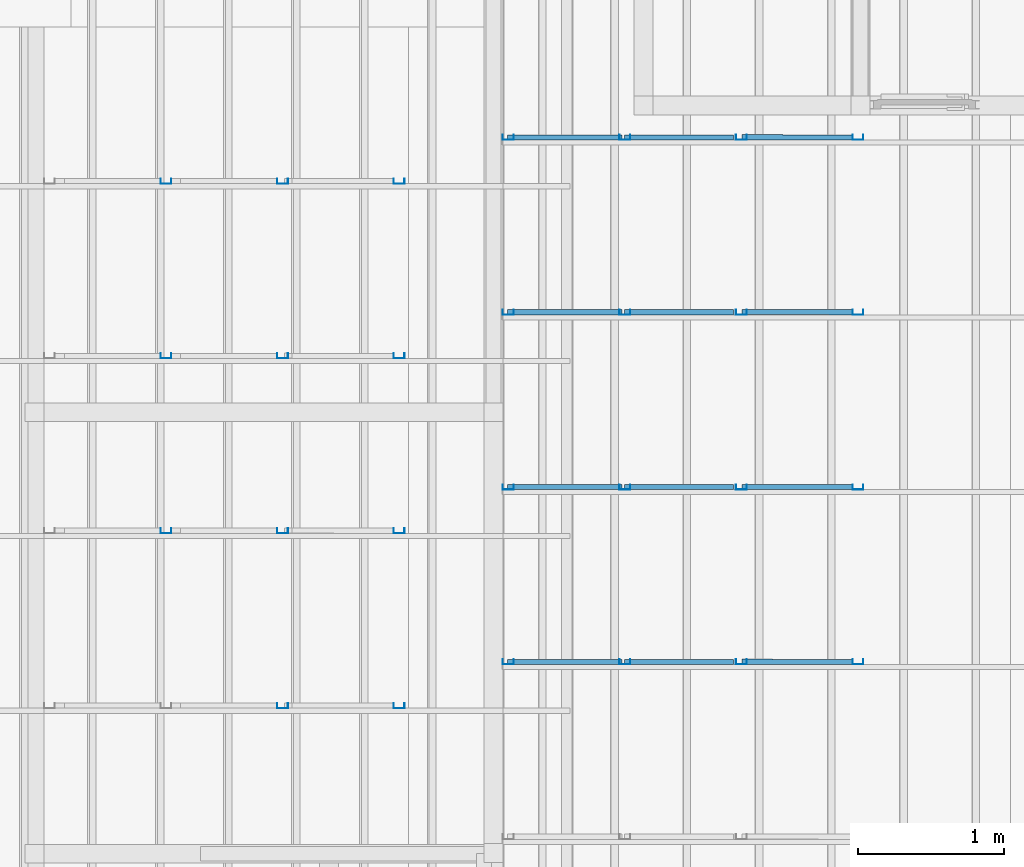
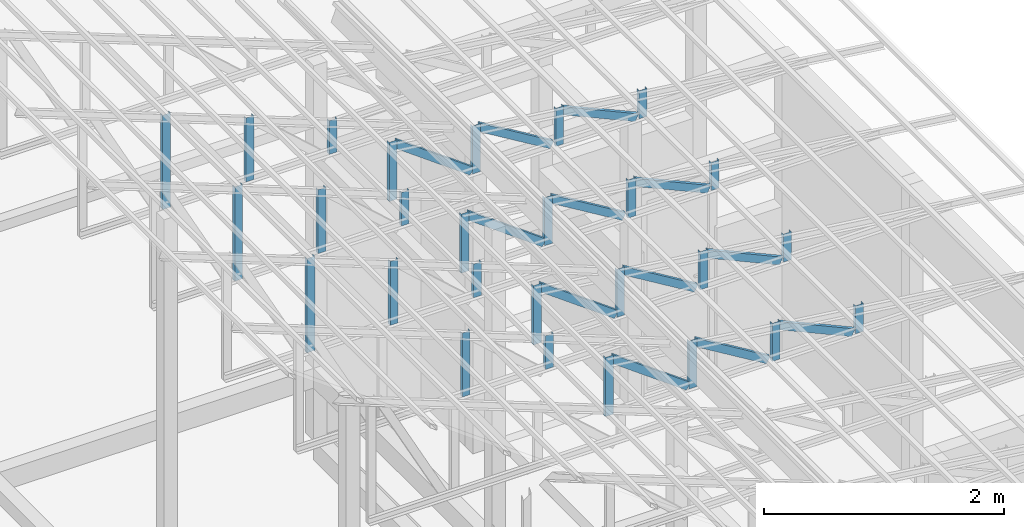
# One storey, part 18 of 22: 39 members, 2 elements without a shape of their own.
"""IFC4 building model written with IfcOpenShell, lengths in millimetres."""

from ifc_helpers import new_model, entity, si_unit, converted_unit, frame, origin_with_axes, origin_2d_with_axis, place, context, subcontext, project, spatial, c_section, extrude, material, material_profile, profile_set, profile_usage, type_object, element, aggregate, save


model = new_model("IFC4")

# Units and contexts
model_context = context("Model", 3, precision=1e-05, world=origin_with_axes())
plan_context = context("Plan", 2, precision=1e-05, world=origin_2d_with_axis())
body_context = subcontext(model_context, "Body", "Model", "MODEL_VIEW")
ifc_project = project(units=[si_unit("VOLUMEUNIT", "CUBIC_METRE"), si_unit("LENGTHUNIT", "METRE", prefix="MILLI"), si_unit("AREAUNIT", "SQUARE_METRE"), converted_unit("PLANEANGLEUNIT", "degree", entity("IfcReal", 0.0174532925199433), si_unit("PLANEANGLEUNIT", "RADIAN"), dimensions=[0, 0, 0, 0, 0, 0, 0])], contexts=[model_context, plan_context])

# Site, building, storey
site_placement = place(None, origin_with_axes())
site = spatial("IfcSite", under=ifc_project, at=site_placement)
building_placement = place(site_placement, origin_with_axes())
building = spatial("IfcBuilding", under=site, at=building_placement, Name="2")
storey_placement = place(building_placement, frame((0.0, 0.0, 200.000002980232), z_axis=(0.0, 0.0, 1.0), x_axis=(1.0, 0.0, 0.0)))
storey = spatial("IfcBuildingStorey", under=building, at=storey_placement)

# Assembly, members
assembly_1_placement = place(storey_placement, frame((-1561.45393848419, 6600.0657081604, 3019.63977515697), z_axis=(0.0, 0.0, 1.0), x_axis=(1.0, 0.0, 0.0)))
assembly_1 = element("IfcElementAssembly", 1, at=assembly_1_placement, inside=storey, Name="K1")
ifc_material = material(Name="STEEL")
ifc_material_profile = material_profile(ifc_material, c_section(Depth=75.0, Width=35.0, WallThickness=1.0, Girth=1.0, kind="CURVE"))
ifc_profile_set = profile_set([ifc_material_profile])
ifc_profile_usage_1 = profile_usage(ifc_profile_set, cardinal=9)
member_type = type_object("IfcMemberType", Name="C75", PredefinedType="CHORD", material=ifc_profile_set)
member_1_placement = place(assembly_1_placement, frame((-702.355027198792, 5999.93181228638, 368.052959442139), z_axis=(0.912206913056706, -0.00121979383816088, -0.409728031594797), x_axis=(0.00137145876901944, 0.999999056639273, 7.62981516029096e-05)))
member_1 = element("IfcMember", 2, at=member_1_placement, type_object=member_type, material=ifc_profile_usage_1, Name="Member", context=body_context, shape_type="SweptSolid", body=[
    extrude(c_section(Depth=75.0, Width=35.0, WallThickness=1.0, Girth=1.0, kind="CURVE"), frame((17.5, -37.5, 0.0), z_axis=(0.0, 0.0, 1.0), x_axis=(1.0, 0.0, 0.0)), (0.0, 0.0, 1.0), 791.494517196627),
])
ifc_profile_usage_2 = profile_usage(ifc_profile_set, cardinal=9)
member_2_placement = place(assembly_1_placement, frame((-2299.51107501984, 5998.93236160278, 592.46301651001), z_axis=(-8.7422719730052e-08, 3.25841369885875e-07, -0.999999999999943), x_axis=(1.62920684942936e-07, 0.999999999999934, 3.25841369885871e-07)))
member_2 = element("IfcMember", 3, at=member_2_placement, type_object=member_type, material=ifc_profile_usage_2, Name="Member", context=body_context, shape_type="SweptSolid", body=[
    extrude(c_section(Depth=75.0, Width=35.0, WallThickness=1.0, Girth=1.0, kind="CURVE"), frame((17.5, -37.5, 0.0), z_axis=(0.0, 0.0, 1.0), x_axis=(1.0, 0.0, 0.0)), (0.0, 0.0, 1.0), 601.479041515268),
])
ifc_profile_usage_3 = profile_usage(ifc_profile_set, cardinal=9)
member_3_placement = place(assembly_1_placement, frame((-1499.51112270355, 5998.93236160278, 479.381561279297), z_axis=(-8.7422719730052e-08, 3.25841369885875e-07, -0.999999999999943), x_axis=(1.62920684942936e-07, 0.999999999999934, 3.25841369885871e-07)))
member_3 = element("IfcMember", 4, at=member_3_placement, type_object=member_type, material=ifc_profile_usage_3, Name="Member", context=body_context, shape_type="SweptSolid", body=[
    extrude(c_section(Depth=75.0, Width=35.0, WallThickness=1.0, Girth=1.0, kind="CURVE"), frame((17.5, -37.5, 0.0), z_axis=(0.0, 0.0, 1.0), x_axis=(1.0, 0.0, 0.0)), (0.0, 0.0, 1.0), 488.397843745656),
])
ifc_profile_usage_4 = profile_usage(ifc_profile_set, cardinal=9)
member_4_placement = place(assembly_1_placement, frame((-699.511170387268, 5998.93236160278, 377.824306488037), z_axis=(-8.7422719730052e-08, 3.25841369885875e-07, -0.999999999999943), x_axis=(1.62920684942936e-07, 0.999999999999934, 3.25841369885871e-07)))
member_4 = element("IfcMember", 5, at=member_4_placement, type_object=member_type, material=ifc_profile_usage_4, Name="Member", context=body_context, shape_type="SweptSolid", body=[
    extrude(c_section(Depth=75.0, Width=35.0, WallThickness=1.0, Girth=1.0, kind="CURVE"), frame((17.5, -37.5, 0.0), z_axis=(0.0, 0.0, 1.0), x_axis=(1.0, 0.0, 0.0)), (0.0, 0.0, 1.0), 386.840589191612),
])
ifc_profile_usage_5 = profile_usage(ifc_profile_set, cardinal=9)
member_5_placement = place(assembly_1_placement, frame((-2299.51107501984, 5998.93236160278, 592.46301651001), z_axis=(0.807471586940316, -1.26964538798404e-07, -0.589906464012789), x_axis=(7.54979012640426e-08, 0.999999999999991, -1.1188575399501e-07)))
member_5 = element("IfcMember", 6, at=member_5_placement, type_object=member_type, material=ifc_profile_usage_5, Name="Member", context=body_context, shape_type="SweptSolid", body=[
    extrude(c_section(Depth=75.0, Width=35.0, WallThickness=1.0, Girth=1.0, kind="CURVE"), frame((17.5, -37.5, 0.0), z_axis=(0.0, 0.0, 1.0), x_axis=(1.0, 0.0, 0.0)), (0.0, 0.0, 1.0), 921.685377112707),
])
ifc_profile_usage_6 = profile_usage(ifc_profile_set, cardinal=9)
member_6_placement = place(assembly_1_placement, frame((-1499.51112270355, 5998.93236160278, 479.381561279297), z_axis=(0.855801528545197, -4.23314648434558e-08, -0.517304304775924), x_axis=(7.5497901264043e-08, 0.999999999999996, 4.30689546249139e-08)))
member_6 = element("IfcMember", 7, at=member_6_placement, type_object=member_type, material=ifc_profile_usage_6, Name="Member", context=body_context, shape_type="SweptSolid", body=[
    extrude(c_section(Depth=75.0, Width=35.0, WallThickness=1.0, Girth=1.0, kind="CURVE"), frame((17.5, -37.5, 0.0), z_axis=(0.0, 0.0, 1.0), x_axis=(1.0, 0.0, 0.0)), (0.0, 0.0, 1.0), 826.976096113964),
])
ifc_profile_usage_7 = profile_usage(ifc_profile_set, cardinal=9)
member_7_placement = place(assembly_1_placement, frame((100.488781929016, 5998.93236160278, 276.402950286865), z_axis=(-8.7422719730052e-08, 3.25841369885875e-07, -0.999999999999943), x_axis=(1.62920684942936e-07, 0.999999999999934, 3.25841369885871e-07)))
member_7 = element("IfcMember", 8, at=member_7_placement, type_object=member_type, material=ifc_profile_usage_7, Name="Member", context=body_context, shape_type="SweptSolid", body=[
    extrude(c_section(Depth=75.0, Width=35.0, WallThickness=1.0, Girth=1.0, kind="CURVE"), frame((17.5, -37.5, 0.0), z_axis=(0.0, 0.0, 1.0), x_axis=(1.0, 0.0, 0.0)), (0.0, 0.0, 1.0), 285.419225275215),
])
ifc_profile_usage_8 = profile_usage(ifc_profile_set, cardinal=9)
member_8_placement = place(assembly_1_placement, frame((-702.355027198792, 7199.93162155151, 368.052959442139), z_axis=(0.912206913056706, -0.00121979383816088, -0.409728031594797), x_axis=(0.00137145876901944, 0.999999056639273, 7.62981516029096e-05)))
member_8 = element("IfcMember", 9, at=member_8_placement, type_object=member_type, material=ifc_profile_usage_8, Name="Member", context=body_context, shape_type="SweptSolid", body=[
    extrude(c_section(Depth=75.0, Width=35.0, WallThickness=1.0, Girth=1.0, kind="CURVE"), frame((17.5, -37.5, 0.0), z_axis=(0.0, 0.0, 1.0), x_axis=(1.0, 0.0, 0.0)), (0.0, 0.0, 1.0), 791.494517196627),
])
ifc_profile_usage_9 = profile_usage(ifc_profile_set, cardinal=9)
member_9_placement = place(assembly_1_placement, frame((-699.511170387268, 7198.93217086792, 377.824306488037), z_axis=(-8.7422719730052e-08, 3.25841369885875e-07, -0.999999999999943), x_axis=(1.62920684942936e-07, 0.999999999999934, 3.25841369885871e-07)))
member_9 = element("IfcMember", 10, at=member_9_placement, type_object=member_type, material=ifc_profile_usage_9, Name="Member", context=body_context, shape_type="SweptSolid", body=[
    extrude(c_section(Depth=75.0, Width=35.0, WallThickness=1.0, Girth=1.0, kind="CURVE"), frame((17.5, -37.5, 0.0), z_axis=(0.0, 0.0, 1.0), x_axis=(1.0, 0.0, 0.0)), (0.0, 0.0, 1.0), 386.840589191612),
])
ifc_profile_usage_10 = profile_usage(ifc_profile_set, cardinal=9)
member_10_placement = place(assembly_1_placement, frame((-2299.51107501984, 7198.93217086792, 592.46301651001), z_axis=(-8.7422719730052e-08, 3.25841369885875e-07, -0.999999999999943), x_axis=(1.62920684942936e-07, 0.999999999999934, 3.25841369885871e-07)))
member_10 = element("IfcMember", 11, at=member_10_placement, type_object=member_type, material=ifc_profile_usage_10, Name="Member", context=body_context, shape_type="SweptSolid", body=[
    extrude(c_section(Depth=75.0, Width=35.0, WallThickness=1.0, Girth=1.0, kind="CURVE"), frame((17.5, -37.5, 0.0), z_axis=(0.0, 0.0, 1.0), x_axis=(1.0, 0.0, 0.0)), (0.0, 0.0, 1.0), 601.479041515268),
])
ifc_profile_usage_11 = profile_usage(ifc_profile_set, cardinal=9)
member_11_placement = place(assembly_1_placement, frame((100.488781929016, 7198.93217086792, 276.402950286865), z_axis=(-8.7422719730052e-08, 3.25841369885875e-07, -0.999999999999943), x_axis=(1.62920684942936e-07, 0.999999999999934, 3.25841369885871e-07)))
member_11 = element("IfcMember", 12, at=member_11_placement, type_object=member_type, material=ifc_profile_usage_11, Name="Member", context=body_context, shape_type="SweptSolid", body=[
    extrude(c_section(Depth=75.0, Width=35.0, WallThickness=1.0, Girth=1.0, kind="CURVE"), frame((17.5, -37.5, 0.0), z_axis=(0.0, 0.0, 1.0), x_axis=(1.0, 0.0, 0.0)), (0.0, 0.0, 1.0), 285.419225275215),
])
ifc_profile_usage_12 = profile_usage(ifc_profile_set, cardinal=9)
member_12_placement = place(assembly_1_placement, frame((-1499.51112270355, 7198.93217086792, 479.381561279297), z_axis=(-8.7422719730052e-08, 3.25841369885875e-07, -0.999999999999943), x_axis=(1.62920684942936e-07, 0.999999999999934, 3.25841369885871e-07)))
member_12 = element("IfcMember", 13, at=member_12_placement, type_object=member_type, material=ifc_profile_usage_12, Name="Member", context=body_context, shape_type="SweptSolid", body=[
    extrude(c_section(Depth=75.0, Width=35.0, WallThickness=1.0, Girth=1.0, kind="CURVE"), frame((17.5, -37.5, 0.0), z_axis=(0.0, 0.0, 1.0), x_axis=(1.0, 0.0, 0.0)), (0.0, 0.0, 1.0), 488.397843745656),
])
ifc_profile_usage_13 = profile_usage(ifc_profile_set, cardinal=9)
member_13_placement = place(assembly_1_placement, frame((-2299.51107501984, 7198.93217086792, 592.46301651001), z_axis=(0.807471586940316, -1.26964538798404e-07, -0.589906464012789), x_axis=(7.54979012640426e-08, 0.999999999999991, -1.1188575399501e-07)))
member_13 = element("IfcMember", 14, at=member_13_placement, type_object=member_type, material=ifc_profile_usage_13, Name="Member", context=body_context, shape_type="SweptSolid", body=[
    extrude(c_section(Depth=75.0, Width=35.0, WallThickness=1.0, Girth=1.0, kind="CURVE"), frame((17.5, -37.5, 0.0), z_axis=(0.0, 0.0, 1.0), x_axis=(1.0, 0.0, 0.0)), (0.0, 0.0, 1.0), 921.685377112707),
])
ifc_profile_usage_14 = profile_usage(ifc_profile_set, cardinal=9)
member_14_placement = place(assembly_1_placement, frame((-1499.51112270355, 7198.93217086792, 479.381561279297), z_axis=(0.855801528545197, -4.23314648434558e-08, -0.517304304775924), x_axis=(7.5497901264043e-08, 0.999999999999996, 4.30689546249139e-08)))
member_14 = element("IfcMember", 15, at=member_14_placement, type_object=member_type, material=ifc_profile_usage_14, Name="Member", context=body_context, shape_type="SweptSolid", body=[
    extrude(c_section(Depth=75.0, Width=35.0, WallThickness=1.0, Girth=1.0, kind="CURVE"), frame((17.5, -37.5, 0.0), z_axis=(0.0, 0.0, 1.0), x_axis=(1.0, 0.0, 0.0)), (0.0, 0.0, 1.0), 826.976096113964),
])
ifc_profile_usage_15 = profile_usage(ifc_profile_set, cardinal=9)
member_15_placement = place(assembly_1_placement, frame((-2299.51107501984, 8398.93198013306, 592.46301651001), z_axis=(-8.7422719730052e-08, 3.25841369885875e-07, -0.999999999999943), x_axis=(1.62920684942936e-07, 0.999999999999934, 3.25841369885871e-07)))
member_15 = element("IfcMember", 16, at=member_15_placement, type_object=member_type, material=ifc_profile_usage_15, Name="Member", context=body_context, shape_type="SweptSolid", body=[
    extrude(c_section(Depth=75.0, Width=35.0, WallThickness=1.0, Girth=1.0, kind="CURVE"), frame((17.5, -37.5, 0.0), z_axis=(0.0, 0.0, 1.0), x_axis=(1.0, 0.0, 0.0)), (0.0, 0.0, 1.0), 601.479041515268),
])
ifc_profile_usage_16 = profile_usage(ifc_profile_set, cardinal=9)
member_16_placement = place(assembly_1_placement, frame((-699.511170387268, 8398.93198013306, 377.824306488037), z_axis=(-8.7422719730052e-08, 3.25841369885875e-07, -0.999999999999943), x_axis=(1.62920684942936e-07, 0.999999999999934, 3.25841369885871e-07)))
member_16 = element("IfcMember", 17, at=member_16_placement, type_object=member_type, material=ifc_profile_usage_16, Name="Member", context=body_context, shape_type="SweptSolid", body=[
    extrude(c_section(Depth=75.0, Width=35.0, WallThickness=1.0, Girth=1.0, kind="CURVE"), frame((17.5, -37.5, 0.0), z_axis=(0.0, 0.0, 1.0), x_axis=(1.0, 0.0, 0.0)), (0.0, 0.0, 1.0), 386.840589191612),
])
ifc_profile_usage_17 = profile_usage(ifc_profile_set, cardinal=9)
member_17_placement = place(assembly_1_placement, frame((100.488781929016, 8398.93198013306, 276.402950286865), z_axis=(-8.7422719730052e-08, 3.25841369885875e-07, -0.999999999999943), x_axis=(1.62920684942936e-07, 0.999999999999934, 3.25841369885871e-07)))
member_17 = element("IfcMember", 18, at=member_17_placement, type_object=member_type, material=ifc_profile_usage_17, Name="Member", context=body_context, shape_type="SweptSolid", body=[
    extrude(c_section(Depth=75.0, Width=35.0, WallThickness=1.0, Girth=1.0, kind="CURVE"), frame((17.5, -37.5, 0.0), z_axis=(0.0, 0.0, 1.0), x_axis=(1.0, 0.0, 0.0)), (0.0, 0.0, 1.0), 285.419225275215),
])
ifc_profile_usage_18 = profile_usage(ifc_profile_set, cardinal=9)
member_18_placement = place(assembly_1_placement, frame((-1499.51112270355, 8398.93198013306, 479.381561279297), z_axis=(-8.7422719730052e-08, 3.25841369885875e-07, -0.999999999999943), x_axis=(1.62920684942936e-07, 0.999999999999934, 3.25841369885871e-07)))
member_18 = element("IfcMember", 19, at=member_18_placement, type_object=member_type, material=ifc_profile_usage_18, Name="Member", context=body_context, shape_type="SweptSolid", body=[
    extrude(c_section(Depth=75.0, Width=35.0, WallThickness=1.0, Girth=1.0, kind="CURVE"), frame((17.5, -37.5, 0.0), z_axis=(0.0, 0.0, 1.0), x_axis=(1.0, 0.0, 0.0)), (0.0, 0.0, 1.0), 488.397843745656),
])
ifc_profile_usage_19 = profile_usage(ifc_profile_set, cardinal=9)
member_19_placement = place(assembly_1_placement, frame((-2299.51107501984, 8398.93198013306, 592.46301651001), z_axis=(0.807471586940316, -1.26964538798404e-07, -0.589906464012789), x_axis=(7.54979012640426e-08, 0.999999999999991, -1.1188575399501e-07)))
member_19 = element("IfcMember", 20, at=member_19_placement, type_object=member_type, material=ifc_profile_usage_19, Name="Member", context=body_context, shape_type="SweptSolid", body=[
    extrude(c_section(Depth=75.0, Width=35.0, WallThickness=1.0, Girth=1.0, kind="CURVE"), frame((17.5, -37.5, 0.0), z_axis=(0.0, 0.0, 1.0), x_axis=(1.0, 0.0, 0.0)), (0.0, 0.0, 1.0), 921.685377112707),
])
ifc_profile_usage_20 = profile_usage(ifc_profile_set, cardinal=9)
member_20_placement = place(assembly_1_placement, frame((-702.355027198792, 8399.93143081665, 368.052959442139), z_axis=(0.912206913056706, -0.00121979383816088, -0.409728031594797), x_axis=(0.00137145876901944, 0.999999056639273, 7.62981516029096e-05)))
member_20 = element("IfcMember", 21, at=member_20_placement, type_object=member_type, material=ifc_profile_usage_20, Name="Member", context=body_context, shape_type="SweptSolid", body=[
    extrude(c_section(Depth=75.0, Width=35.0, WallThickness=1.0, Girth=1.0, kind="CURVE"), frame((17.5, -37.5, 0.0), z_axis=(0.0, 0.0, 1.0), x_axis=(1.0, 0.0, 0.0)), (0.0, 0.0, 1.0), 791.494517196627),
])
ifc_profile_usage_21 = profile_usage(ifc_profile_set, cardinal=9)
member_21_placement = place(assembly_1_placement, frame((-1499.51112270355, 8398.93198013306, 479.381561279297), z_axis=(0.855801528545197, -4.23314648434558e-08, -0.517304304775924), x_axis=(7.5497901264043e-08, 0.999999999999996, 4.30689546249139e-08)))
member_21 = element("IfcMember", 22, at=member_21_placement, type_object=member_type, material=ifc_profile_usage_21, Name="Member", context=body_context, shape_type="SweptSolid", body=[
    extrude(c_section(Depth=75.0, Width=35.0, WallThickness=1.0, Girth=1.0, kind="CURVE"), frame((17.5, -37.5, 0.0), z_axis=(0.0, 0.0, 1.0), x_axis=(1.0, 0.0, 0.0)), (0.0, 0.0, 1.0), 826.976096113964),
])
ifc_profile_usage_22 = profile_usage(ifc_profile_set, cardinal=9)
member_22_placement = place(assembly_1_placement, frame((-2299.51107501984, 9598.93178939819, 592.46301651001), z_axis=(-8.7422719730052e-08, 3.25841369885875e-07, -0.999999999999943), x_axis=(1.62920684942936e-07, 0.999999999999934, 3.25841369885871e-07)))
member_22 = element("IfcMember", 23, at=member_22_placement, type_object=member_type, material=ifc_profile_usage_22, Name="Member", context=body_context, shape_type="SweptSolid", body=[
    extrude(c_section(Depth=75.0, Width=35.0, WallThickness=1.0, Girth=1.0, kind="CURVE"), frame((17.5, -37.5, 0.0), z_axis=(0.0, 0.0, 1.0), x_axis=(1.0, 0.0, 0.0)), (0.0, 0.0, 1.0), 601.479041515268),
])
ifc_profile_usage_23 = profile_usage(ifc_profile_set, cardinal=9)
member_23_placement = place(assembly_1_placement, frame((-1499.51112270355, 9598.93178939819, 479.381561279297), z_axis=(-8.7422719730052e-08, 3.25841369885875e-07, -0.999999999999943), x_axis=(1.62920684942936e-07, 0.999999999999934, 3.25841369885871e-07)))
member_23 = element("IfcMember", 24, at=member_23_placement, type_object=member_type, material=ifc_profile_usage_23, Name="Member", context=body_context, shape_type="SweptSolid", body=[
    extrude(c_section(Depth=75.0, Width=35.0, WallThickness=1.0, Girth=1.0, kind="CURVE"), frame((17.5, -37.5, 0.0), z_axis=(0.0, 0.0, 1.0), x_axis=(1.0, 0.0, 0.0)), (0.0, 0.0, 1.0), 488.397843745656),
])
ifc_profile_usage_24 = profile_usage(ifc_profile_set, cardinal=9)
member_24_placement = place(assembly_1_placement, frame((-702.355027198792, 9599.93124008179, 368.052959442139), z_axis=(0.912206913056706, -0.00121979383816088, -0.409728031594797), x_axis=(0.00137145876901944, 0.999999056639273, 7.62981516029096e-05)))
member_24 = element("IfcMember", 25, at=member_24_placement, type_object=member_type, material=ifc_profile_usage_24, Name="Member", context=body_context, shape_type="SweptSolid", body=[
    extrude(c_section(Depth=75.0, Width=35.0, WallThickness=1.0, Girth=1.0, kind="CURVE"), frame((17.5, -37.5, 0.0), z_axis=(0.0, 0.0, 1.0), x_axis=(1.0, 0.0, 0.0)), (0.0, 0.0, 1.0), 791.494517196627),
])
ifc_profile_usage_25 = profile_usage(ifc_profile_set, cardinal=9)
member_25_placement = place(assembly_1_placement, frame((-1499.51112270355, 9598.93178939819, 479.381561279297), z_axis=(0.855801528545197, -4.23314648434558e-08, -0.517304304775924), x_axis=(7.5497901264043e-08, 0.999999999999996, 4.30689546249139e-08)))
member_25 = element("IfcMember", 26, at=member_25_placement, type_object=member_type, material=ifc_profile_usage_25, Name="Member", context=body_context, shape_type="SweptSolid", body=[
    extrude(c_section(Depth=75.0, Width=35.0, WallThickness=1.0, Girth=1.0, kind="CURVE"), frame((17.5, -37.5, 0.0), z_axis=(0.0, 0.0, 1.0), x_axis=(1.0, 0.0, 0.0)), (0.0, 0.0, 1.0), 826.976096113964),
])
ifc_profile_usage_26 = profile_usage(ifc_profile_set, cardinal=9)
member_26_placement = place(assembly_1_placement, frame((-2299.51107501984, 9598.93178939819, 592.46301651001), z_axis=(0.807471586940316, -1.26964538798404e-07, -0.589906464012789), x_axis=(7.54979012640426e-08, 0.999999999999991, -1.1188575399501e-07)))
member_26 = element("IfcMember", 27, at=member_26_placement, type_object=member_type, material=ifc_profile_usage_26, Name="Member", context=body_context, shape_type="SweptSolid", body=[
    extrude(c_section(Depth=75.0, Width=35.0, WallThickness=1.0, Girth=1.0, kind="CURVE"), frame((17.5, -37.5, 0.0), z_axis=(0.0, 0.0, 1.0), x_axis=(1.0, 0.0, 0.0)), (0.0, 0.0, 1.0), 921.685377112707),
])
ifc_profile_usage_27 = profile_usage(ifc_profile_set, cardinal=9)
member_27_placement = place(assembly_1_placement, frame((-699.511170387268, 9598.93178939819, 377.824306488037), z_axis=(-8.7422719730052e-08, 3.25841369885875e-07, -0.999999999999943), x_axis=(1.62920684942936e-07, 0.999999999999934, 3.25841369885871e-07)))
member_27 = element("IfcMember", 28, at=member_27_placement, type_object=member_type, material=ifc_profile_usage_27, Name="Member", context=body_context, shape_type="SweptSolid", body=[
    extrude(c_section(Depth=75.0, Width=35.0, WallThickness=1.0, Girth=1.0, kind="CURVE"), frame((17.5, -37.5, 0.0), z_axis=(0.0, 0.0, 1.0), x_axis=(1.0, 0.0, 0.0)), (0.0, 0.0, 1.0), 386.840589191612),
])
ifc_profile_usage_28 = profile_usage(ifc_profile_set, cardinal=9)
member_28_placement = place(assembly_1_placement, frame((100.488781929016, 9598.93178939819, 276.402950286865), z_axis=(-8.7422719730052e-08, 3.25841369885875e-07, -0.999999999999943), x_axis=(1.62920684942936e-07, 0.999999999999934, 3.25841369885871e-07)))
member_28 = element("IfcMember", 29, at=member_28_placement, type_object=member_type, material=ifc_profile_usage_28, Name="Member", context=body_context, shape_type="SweptSolid", body=[
    extrude(c_section(Depth=75.0, Width=35.0, WallThickness=1.0, Girth=1.0, kind="CURVE"), frame((17.5, -37.5, 0.0), z_axis=(0.0, 0.0, 1.0), x_axis=(1.0, 0.0, 0.0)), (0.0, 0.0, 1.0), 285.419225275215),
])
aggregate(assembly_1, [member_1, member_2, member_3, member_4, member_5, member_6, member_7, member_8, member_9, member_10, member_11, member_12, member_13, member_14, member_15, member_16, member_17, member_18, member_19, member_20, member_21, member_22, member_23, member_24, member_25, member_26, member_27, member_28])

assembly_2_placement = place(storey_placement, frame((-3938.51041793823, 5099.00283813477, 3935.3459328413), z_axis=(0.0, 0.0, 1.0), x_axis=(1.0, 0.0, 0.0)))
assembly_2 = element("IfcElementAssembly", 30, at=assembly_2_placement, inside=storey, Name="2")
ifc_profile_usage_29 = profile_usage(ifc_profile_set, cardinal=1)
member_29_placement = place(assembly_2_placement, frame((-1546.51069641113, 7234.99774932861, 648.419380187988), z_axis=(-8.74227410463377e-08, -1.50995830949794e-07, -0.999999999999985), x_axis=(-3.13916473260159e-07, 0.999999999999939, -1.50995802528077e-07)))
member_29 = element("IfcMember", 31, at=member_29_placement, type_object=member_type, material=ifc_profile_usage_29, Name="Member", context=body_context, shape_type="SweptSolid", body=[
    extrude(c_section(Depth=75.0, Width=35.0, WallThickness=1.0, Girth=1.0, kind="CURVE"), frame((-17.5, 37.5, 0.0), z_axis=(0.0, 0.0, 1.0), x_axis=(1.0, 0.0, 0.0)), (0.0, 0.0, 1.0), 649.773129888493),
])
ifc_profile_usage_30 = profile_usage(ifc_profile_set, cardinal=1)
member_30_placement = place(assembly_2_placement, frame((-746.51050567627, 7234.99774932861, 339.939117431641), z_axis=(-8.74227410463377e-08, -1.50995830949794e-07, -0.999999999999985), x_axis=(-3.13916473260159e-07, 0.999999999999939, -1.50995802528077e-07)))
member_30 = element("IfcMember", 32, at=member_30_placement, type_object=member_type, material=ifc_profile_usage_30, Name="Member", context=body_context, shape_type="SweptSolid", body=[
    extrude(c_section(Depth=75.0, Width=35.0, WallThickness=1.0, Girth=1.0, kind="CURVE"), frame((-17.5, 37.5, 0.0), z_axis=(0.0, 0.0, 1.0), x_axis=(1.0, 0.0, 0.0)), (0.0, 0.0, 1.0), 341.292854350017),
])
ifc_profile_usage_31 = profile_usage(ifc_profile_set, cardinal=1)
member_31_placement = place(assembly_2_placement, frame((-1546.51069641113, 8434.99755859375, 648.419380187988), z_axis=(-8.74227410463377e-08, -1.50995830949794e-07, -0.999999999999985), x_axis=(-3.13916473260159e-07, 0.999999999999939, -1.50995802528077e-07)))
member_31 = element("IfcMember", 33, at=member_31_placement, type_object=member_type, material=ifc_profile_usage_31, Name="Member", context=body_context, shape_type="SweptSolid", body=[
    extrude(c_section(Depth=75.0, Width=35.0, WallThickness=1.0, Girth=1.0, kind="CURVE"), frame((-17.5, 37.5, 0.0), z_axis=(0.0, 0.0, 1.0), x_axis=(1.0, 0.0, 0.0)), (0.0, 0.0, 1.0), 649.773129888493),
])
ifc_profile_usage_32 = profile_usage(ifc_profile_set, cardinal=1)
member_32_placement = place(assembly_2_placement, frame((-746.51050567627, 8434.99755859375, 339.939117431641), z_axis=(-8.74227410463377e-08, -1.50995830949794e-07, -0.999999999999985), x_axis=(-3.13916473260159e-07, 0.999999999999939, -1.50995802528077e-07)))
member_32 = element("IfcMember", 34, at=member_32_placement, type_object=member_type, material=ifc_profile_usage_32, Name="Member", context=body_context, shape_type="SweptSolid", body=[
    extrude(c_section(Depth=75.0, Width=35.0, WallThickness=1.0, Girth=1.0, kind="CURVE"), frame((-17.5, 37.5, 0.0), z_axis=(0.0, 0.0, 1.0), x_axis=(1.0, 0.0, 0.0)), (0.0, 0.0, 1.0), 341.292854350017),
])
ifc_profile_usage_33 = profile_usage(ifc_profile_set, cardinal=1)
member_33_placement = place(assembly_2_placement, frame((-2346.510887146, 8434.99755859375, 957.056522369385), z_axis=(-8.74227410463377e-08, -1.50995830949794e-07, -0.999999999999985), x_axis=(-3.13916473260159e-07, 0.999999999999939, -1.50995802528077e-07)))
member_33 = element("IfcMember", 35, at=member_33_placement, type_object=member_type, material=ifc_profile_usage_33, Name="Member", context=body_context, shape_type="SweptSolid", body=[
    extrude(c_section(Depth=75.0, Width=35.0, WallThickness=1.0, Girth=1.0, kind="CURVE"), frame((-17.5, 37.5, 0.0), z_axis=(0.0, 0.0, 1.0), x_axis=(1.0, 0.0, 0.0)), (0.0, 0.0, 1.0), 958.410273794281),
])
ifc_profile_usage_34 = profile_usage(ifc_profile_set, cardinal=1)
member_34_placement = place(assembly_2_placement, frame((-1546.51069641113, 9634.99736785889, 648.419380187988), z_axis=(-8.74227410463377e-08, -1.50995830949794e-07, -0.999999999999985), x_axis=(-3.13916473260159e-07, 0.999999999999939, -1.50995802528077e-07)))
member_34 = element("IfcMember", 36, at=member_34_placement, type_object=member_type, material=ifc_profile_usage_34, Name="Member", context=body_context, shape_type="SweptSolid", body=[
    extrude(c_section(Depth=75.0, Width=35.0, WallThickness=1.0, Girth=1.0, kind="CURVE"), frame((-17.5, 37.5, 0.0), z_axis=(0.0, 0.0, 1.0), x_axis=(1.0, 0.0, 0.0)), (0.0, 0.0, 1.0), 649.773129888493),
])
ifc_profile_usage_35 = profile_usage(ifc_profile_set, cardinal=1)
member_35_placement = place(assembly_2_placement, frame((-746.51050567627, 9634.99736785889, 339.939117431641), z_axis=(-8.74227410463377e-08, -1.50995830949794e-07, -0.999999999999985), x_axis=(-3.13916473260159e-07, 0.999999999999939, -1.50995802528077e-07)))
member_35 = element("IfcMember", 37, at=member_35_placement, type_object=member_type, material=ifc_profile_usage_35, Name="Member", context=body_context, shape_type="SweptSolid", body=[
    extrude(c_section(Depth=75.0, Width=35.0, WallThickness=1.0, Girth=1.0, kind="CURVE"), frame((-17.5, 37.5, 0.0), z_axis=(0.0, 0.0, 1.0), x_axis=(1.0, 0.0, 0.0)), (0.0, 0.0, 1.0), 341.292854350017),
])
ifc_profile_usage_36 = profile_usage(ifc_profile_set, cardinal=1)
member_36_placement = place(assembly_2_placement, frame((-2346.510887146, 9634.99736785889, 957.056522369385), z_axis=(-8.74227410463377e-08, -1.50995830949794e-07, -0.999999999999985), x_axis=(-3.13916473260159e-07, 0.999999999999939, -1.50995802528077e-07)))
member_36 = element("IfcMember", 38, at=member_36_placement, type_object=member_type, material=ifc_profile_usage_36, Name="Member", context=body_context, shape_type="SweptSolid", body=[
    extrude(c_section(Depth=75.0, Width=35.0, WallThickness=1.0, Girth=1.0, kind="CURVE"), frame((-17.5, 37.5, 0.0), z_axis=(0.0, 0.0, 1.0), x_axis=(1.0, 0.0, 0.0)), (0.0, 0.0, 1.0), 958.410273794281),
])
ifc_profile_usage_37 = profile_usage(ifc_profile_set, cardinal=1)
member_37_placement = place(assembly_2_placement, frame((-2346.510887146, 10834.997177124, 957.056522369385), z_axis=(-8.74227410463377e-08, -1.50995830949794e-07, -0.999999999999985), x_axis=(-3.13916473260159e-07, 0.999999999999939, -1.50995802528077e-07)))
member_37 = element("IfcMember", 39, at=member_37_placement, type_object=member_type, material=ifc_profile_usage_37, Name="Member", context=body_context, shape_type="SweptSolid", body=[
    extrude(c_section(Depth=75.0, Width=35.0, WallThickness=1.0, Girth=1.0, kind="CURVE"), frame((-17.5, 37.5, 0.0), z_axis=(0.0, 0.0, 1.0), x_axis=(1.0, 0.0, 0.0)), (0.0, 0.0, 1.0), 958.410273794281),
])
ifc_profile_usage_38 = profile_usage(ifc_profile_set, cardinal=1)
member_38_placement = place(assembly_2_placement, frame((-1546.51069641113, 10834.997177124, 648.419380187988), z_axis=(-8.74227410463377e-08, -1.50995830949794e-07, -0.999999999999985), x_axis=(-3.13916473260159e-07, 0.999999999999939, -1.50995802528077e-07)))
member_38 = element("IfcMember", 40, at=member_38_placement, type_object=member_type, material=ifc_profile_usage_38, Name="Member", context=body_context, shape_type="SweptSolid", body=[
    extrude(c_section(Depth=75.0, Width=35.0, WallThickness=1.0, Girth=1.0, kind="CURVE"), frame((-17.5, 37.5, 0.0), z_axis=(0.0, 0.0, 1.0), x_axis=(1.0, 0.0, 0.0)), (0.0, 0.0, 1.0), 649.773129888493),
])
ifc_profile_usage_39 = profile_usage(ifc_profile_set, cardinal=1)
member_39_placement = place(assembly_2_placement, frame((-746.51050567627, 10834.997177124, 339.939117431641), z_axis=(-8.74227410463377e-08, -1.50995830949794e-07, -0.999999999999985), x_axis=(-3.13916473260159e-07, 0.999999999999939, -1.50995802528077e-07)))
member_39 = element("IfcMember", 41, at=member_39_placement, type_object=member_type, material=ifc_profile_usage_39, Name="Member", context=body_context, shape_type="SweptSolid", body=[
    extrude(c_section(Depth=75.0, Width=35.0, WallThickness=1.0, Girth=1.0, kind="CURVE"), frame((-17.5, 37.5, 0.0), z_axis=(0.0, 0.0, 1.0), x_axis=(1.0, 0.0, 0.0)), (0.0, 0.0, 1.0), 341.292854350017),
])
aggregate(assembly_2, [member_29, member_30, member_31, member_32, member_33, member_34, member_35, member_36, member_37, member_38, member_39])

save(model, "model.ifc")
